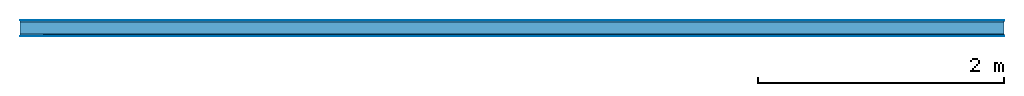
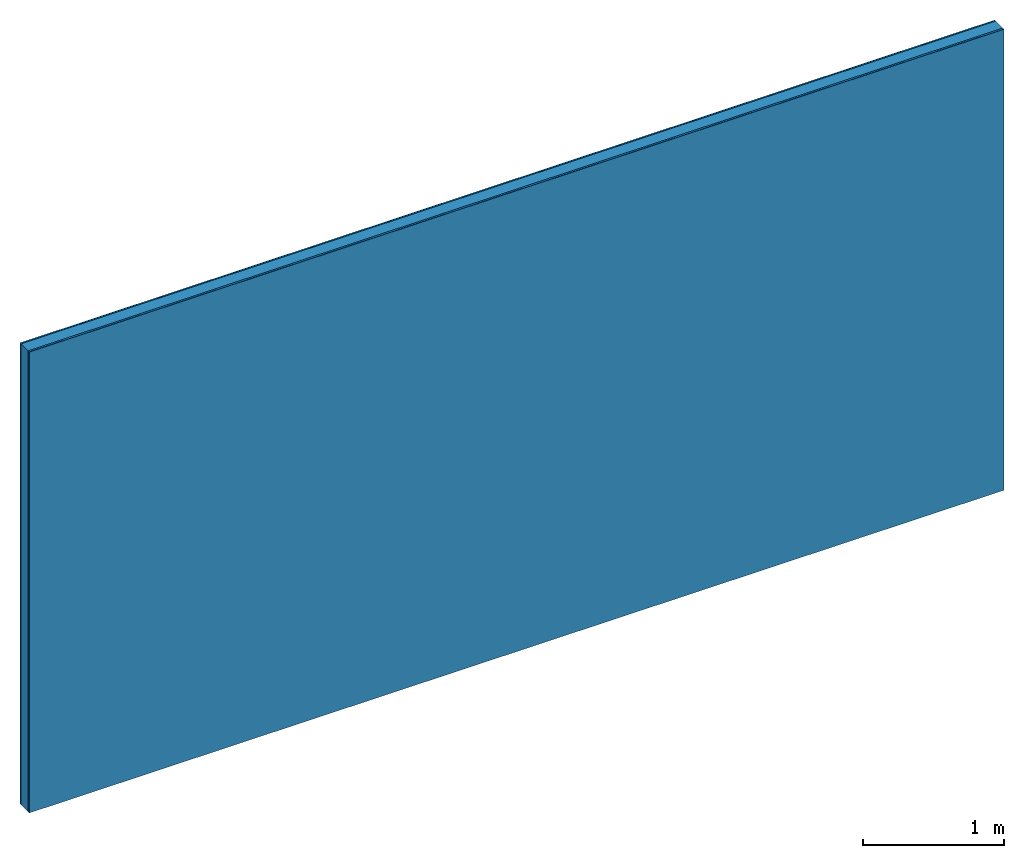
# One storey: 4 plates, 1 member, 1 element without a shape of its own.
"""IFC4 building model written with IfcOpenShell, lengths in metres."""

from ifc_helpers import new_model, si_unit, derived_unit, direction, frame, frame_2d, origin, origin_with_axes, place, context, project, spatial, rectangle, extrude, material, layer, layer_set, type_object, element, aggregate, save


model = new_model("IFC4")

# Units and contexts
plan_context = context("Plan", 3, precision=1e-05, world=origin(), true_north=direction((0.0, 1.0)))
model_context = context("Model", 3, precision=1e-05, world=origin(), true_north=direction((0.0, 1.0)))
ifc_project = project(units=[si_unit("LENGTHUNIT", "METRE"), derived_unit("SOUNDPRESSUREUNIT", [(si_unit("PRESSUREUNIT", "PASCAL", prefix="MICRO"), 0)]), si_unit("ENERGYUNIT", "JOULE", prefix="MEGA"), si_unit("MASSUNIT", "GRAM", prefix="KILO"), derived_unit("THERMALTRANSMITTANCEUNIT", [(si_unit("POWERUNIT", "WATT"), 1), (si_unit("AREAUNIT", "SQUARE_METRE"), -1), (si_unit("THERMODYNAMICTEMPERATUREUNIT", "KELVIN"), -1)]), derived_unit("AREADENSITYUNIT", [(si_unit("MASSUNIT", "GRAM", prefix="KILO"), 1), (si_unit("AREAUNIT", "SQUARE_METRE"), -1)]), derived_unit("USERDEFINED", [(si_unit("ENERGYUNIT", "JOULE", prefix="MEGA"), 1), (si_unit("AREAUNIT", "SQUARE_METRE"), -1)])], contexts=[plan_context, model_context])

# Site, building, storey
site = spatial("IfcSite", under=ifc_project)
building_placement = place(None, origin())
building = spatial("IfcBuilding", under=site, at=building_placement)
storey_placement = place(building_placement, origin())
storey = spatial("IfcBuildingStorey", under=building, at=storey_placement)

# Wall, member, plates
ifc_material_1 = material(Category="04.001")
ifc_layer_1 = layer(ifc_material_1, 0.003, Name="Surface")
ifc_material_2 = material(Name="Plasterboard type A", Category="03.008")
ifc_layer_2 = layer(ifc_material_2, 0.0125, Name="1st layer")
ifc_material_3 = material(Name="of the art")
ifc_layer_3 = layer(ifc_material_3, 0.0, Name="Bond")
ifc_layer_4 = layer(None, 0.1, Name="Support")
ifc_layer_5 = layer(ifc_material_3, 0.0, Name="Bond")
ifc_material_4 = material(Name="DFH2IR Knauf Diamant hard- plasterboard", Category="03.007")
ifc_layer_6 = layer(ifc_material_4, 0.015, Name="1st layer")
ifc_layer_7 = layer(ifc_material_1, 0.003, Name="Surface")
ifc_layer_set = layer_set([ifc_layer_1, ifc_layer_2, ifc_layer_3, ifc_layer_4, ifc_layer_5, ifc_layer_6, ifc_layer_7])
wall_type = type_object("IfcWallType", Name="C0364", PredefinedType="NOTDEFINED", material=ifc_layer_set)
wall_placement = place(None, frame((0.0, 0.0, 0.0), z_axis=(0.0, -1.0, 0.0), x_axis=(1.0, 0.0, 0.0)))
wall = element("IfcWall", 1, at=wall_placement, inside=storey, type_object=wall_type, material=ifc_layer_set, Name="Wall #1")
ifc_material_5 = material(Name="Solid timber panel")
member_placement = place(wall_placement, origin())
member = element("IfcMember", 2, at=member_placement, material=ifc_material_5, Name="Support", context=plan_context, shape_type="SweptSolid", body=[
    extrude(rectangle(XDim=1.0, YDim=0.1, at=frame_2d((0.5, 0.05), x_axis=(1.0, 0.0))), frame((0.0, 4.0, 0.0155), z_axis=(0.0, -1.0, 0.0), x_axis=(1.0, 0.0, 0.0)), (0.0, 0.0, 1.0), 4.0),
    extrude(rectangle(XDim=1.0, YDim=0.1, at=frame_2d((0.5, 0.05), x_axis=(1.0, 0.0))), frame((1.0, 4.0, 0.0155), z_axis=(0.0, -1.0, 0.0), x_axis=(1.0, 0.0, 0.0)), (0.0, 0.0, 1.0), 4.0),
    extrude(rectangle(XDim=1.0, YDim=0.1, at=frame_2d((0.5, 0.05), x_axis=(1.0, 0.0))), frame((2.0, 4.0, 0.0155), z_axis=(0.0, -1.0, 0.0), x_axis=(1.0, 0.0, 0.0)), (0.0, 0.0, 1.0), 4.0),
    extrude(rectangle(XDim=1.0, YDim=0.1, at=frame_2d((0.5, 0.05), x_axis=(1.0, 0.0))), frame((3.0, 4.0, 0.0155), z_axis=(0.0, -1.0, 0.0), x_axis=(1.0, 0.0, 0.0)), (0.0, 0.0, 1.0), 4.0),
    extrude(rectangle(XDim=1.0, YDim=0.1, at=frame_2d((0.5, 0.05), x_axis=(1.0, 0.0))), frame((4.0, 4.0, 0.0155), z_axis=(0.0, -1.0, 0.0), x_axis=(1.0, 0.0, 0.0)), (0.0, 0.0, 1.0), 4.0),
    extrude(rectangle(XDim=1.0, YDim=0.1, at=frame_2d((0.5, 0.05), x_axis=(1.0, 0.0))), frame((5.0, 4.0, 0.0155), z_axis=(0.0, -1.0, 0.0), x_axis=(1.0, 0.0, 0.0)), (0.0, 0.0, 1.0), 4.0),
    extrude(rectangle(XDim=1.0, YDim=0.1, at=frame_2d((0.5, 0.05), x_axis=(1.0, 0.0))), frame((6.0, 4.0, 0.0155), z_axis=(0.0, -1.0, 0.0), x_axis=(1.0, 0.0, 0.0)), (0.0, 0.0, 1.0), 4.0),
    extrude(rectangle(XDim=1.0, YDim=0.1, at=frame_2d((0.5, 0.05), x_axis=(1.0, 0.0))), frame((7.0, 4.0, 0.0155), z_axis=(0.0, -1.0, 0.0), x_axis=(1.0, 0.0, 0.0)), (0.0, 0.0, 1.0), 4.0),
])
plate_1_placement = place(wall_placement, origin())
plate_1 = element("IfcPlate", 3, at=plate_1_placement, material=ifc_material_1, Name="Surface", context=plan_context, shape_type="SweptSolid", body=[
    extrude(rectangle(XDim=8.0, YDim=4.0, at=frame_2d((4.0, 2.0), x_axis=(1.0, 0.0))), origin_with_axes(), (0.0, 0.0, 1.0), 0.003),
])
plate_2_placement = place(wall_placement, origin())
plate_2 = element("IfcPlate", 4, at=plate_2_placement, material=ifc_material_2, Name="1st layer", context=plan_context, shape_type="SweptSolid", body=[
    extrude(rectangle(XDim=8.0, YDim=4.0, at=frame_2d((4.0, 2.0), x_axis=(1.0, 0.0))), frame((0.0, 0.0, 0.003), z_axis=(0.0, 0.0, 1.0), x_axis=(1.0, 0.0, 0.0)), (0.0, 0.0, 1.0), 0.0125),
])
plate_3_placement = place(wall_placement, origin())
plate_3 = element("IfcPlate", 5, at=plate_3_placement, material=ifc_material_4, Name="1st layer", context=plan_context, shape_type="SweptSolid", body=[
    extrude(rectangle(XDim=8.0, YDim=4.0, at=frame_2d((4.0, 2.0), x_axis=(1.0, 0.0))), frame((0.0, 0.0, 0.1155), z_axis=(0.0, 0.0, 1.0), x_axis=(1.0, 0.0, 0.0)), (0.0, 0.0, 1.0), 0.015),
])
plate_4_placement = place(wall_placement, origin())
plate_4 = element("IfcPlate", 6, at=plate_4_placement, material=ifc_material_1, Name="Surface", context=plan_context, shape_type="SweptSolid", body=[
    extrude(rectangle(XDim=8.0, YDim=4.0, at=frame_2d((4.0, 2.0), x_axis=(1.0, 0.0))), frame((0.0, 0.0, 0.1305), z_axis=(0.0, 0.0, 1.0), x_axis=(1.0, 0.0, 0.0)), (0.0, 0.0, 1.0), 0.003),
])
aggregate(wall, [plate_1, plate_2, member, plate_3, plate_4])

save(model, "model.ifc")
